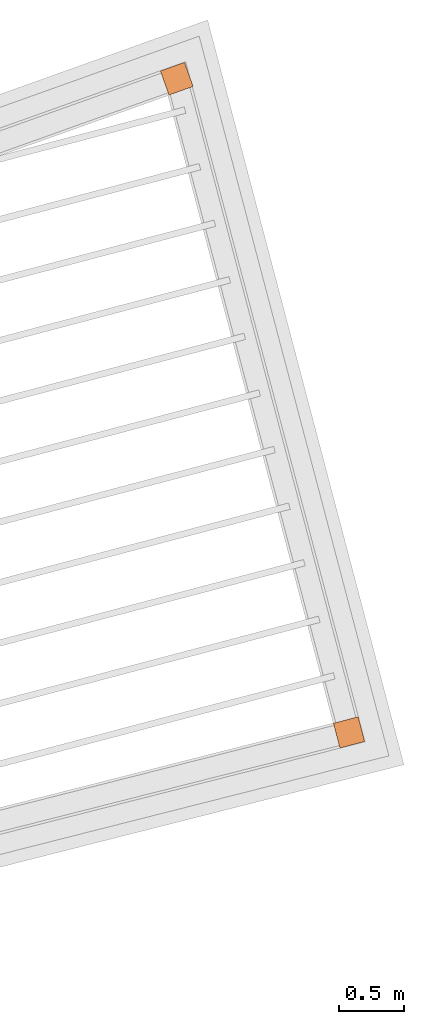
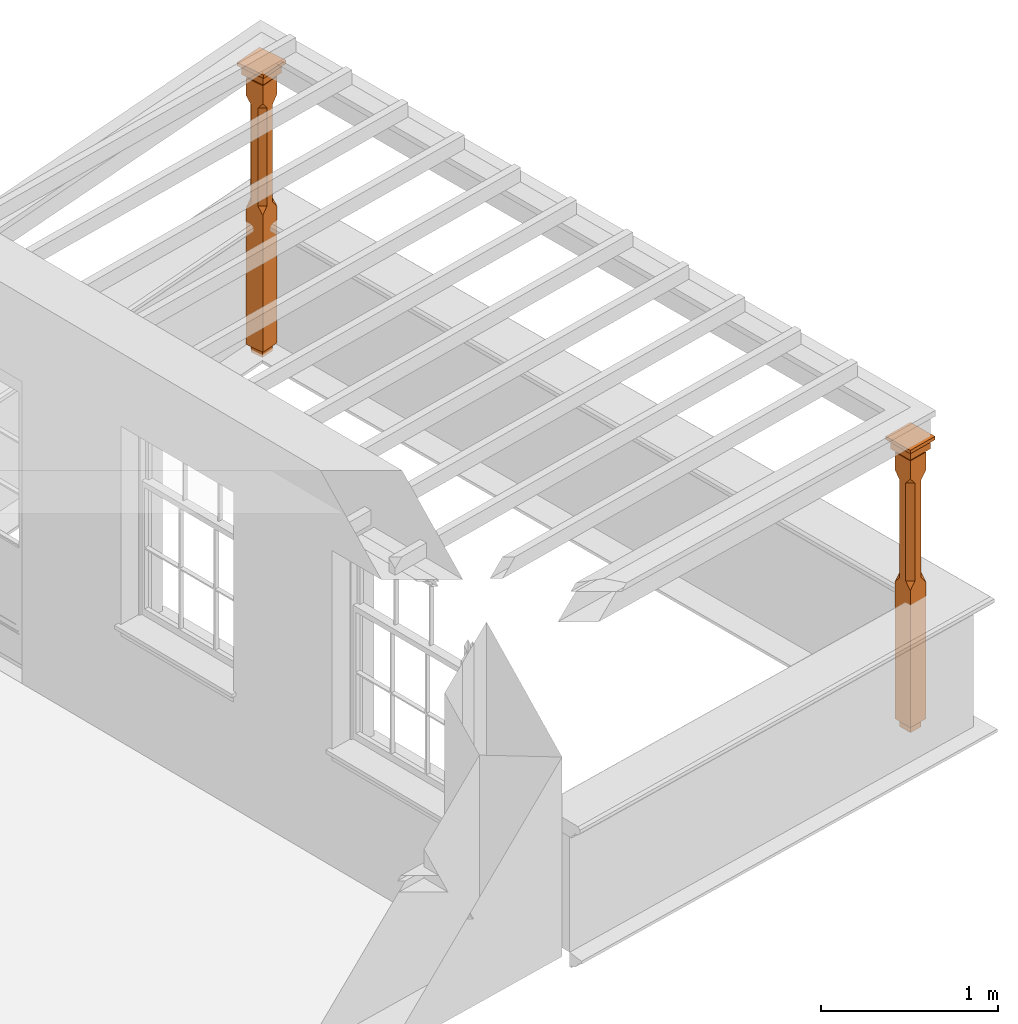
# One storey, part 10 of 10: 2 proxies.
"""IFC2X3 building model written with IfcOpenShell, lengths in metres."""

import ifcopenshell
import ifcopenshell.guid

model = None  # the IFC model being written
_history = None  # IfcOwnerHistory: only IFC2X3 demands one
_inside = {}  # id of a spatial element -> (the spatial element, [elements in it])
_under = {}  # id of a project, library or spatial element -> (it, [spatial elements below it])
_declared = {}  # id of a project -> (the project, [libraries it declares])
_typed = {}  # id of a type object -> (the type object, [elements of that type])
_made_of = {}  # id of a material, layer set ... -> (it, [elements and type objects made of it])


def new_model(schema):
    """Start an empty IFC model of exactly this schema.

    Asked for "IFC4X3", IfcOpenShell would pick the latest addendum, in which some entities
    have other attributes; the version numbers below select the first issue.
    IFC2X3 requires an IfcOwnerHistory on every rooted entity: one is made here for all.
    """
    global model, _history
    if schema == "IFC4X3":
        model = ifcopenshell.file(schema_version=(4, 3, 0, 0))
    else:
        model = ifcopenshell.file(schema=schema)
    _inside.clear()
    _under.clear()
    _declared.clear()
    _typed.clear()
    _made_of.clear()
    _history = None
    if model.schema == "IFC2X3":
        org = make("IfcOrganization", Name="unknown")
        user = make(
            "IfcPersonAndOrganization",
            ThePerson=make("IfcPerson", FamilyName="unknown"),
            TheOrganization=org,
        )
        app = make(
            "IfcApplication",
            ApplicationDeveloper=org,
            Version="unknown",
            ApplicationFullName="unknown",
            ApplicationIdentifier="unknown",
        )
        _history = make(
            "IfcOwnerHistory",
            OwningUser=user,
            OwningApplication=app,
            ChangeAction="ADDED",
            CreationDate=0,
        )
    return model


def make(cls, **values):
    """One entity of the class cls with the attributes given. An attribute that is None is left unset."""
    return model.create_entity(
        cls, **{name: value for name, value in values.items() if value is not None}
    )


def rooted(cls, **values):
    """An entity with a GlobalId (a new one), such as an element, a storey or a relation."""
    return make(cls, GlobalId=ifcopenshell.guid.new(), OwnerHistory=_history, **values)


def si_unit(unit_type, name, prefix=None):
    """IfcSIUnit, for example si_unit("LENGTHUNIT", "METRE", prefix="MILLI")."""
    return make("IfcSIUnit", UnitType=unit_type, Prefix=prefix, Name=name)


def assignment(units):
    """IfcUnitAssignment: the units of a project."""
    return None if units is None else make("IfcUnitAssignment", Units=units)


def point(xyz):
    """IfcCartesianPoint."""
    return None if xyz is None else make("IfcCartesianPoint", Coordinates=xyz)


def direction(xyz):
    """IfcDirection."""
    return None if xyz is None else make("IfcDirection", DirectionRatios=xyz)


def frame(location, z_axis=None, x_axis=None):
    """IfcAxis2Placement3D, a coordinate frame: its origin and axes. An axis left out is left unset."""
    return make(
        "IfcAxis2Placement3D",
        Location=point(location),
        Axis=direction(z_axis),
        RefDirection=direction(x_axis),
    )


def origin():
    """The frame at (0, 0, 0) with its axes left unset."""
    return frame((0.0, 0.0, 0.0))


def place(relative_to, where):
    """IfcLocalPlacement: puts the frame where relative to a parent placement (None: the world)."""
    return make(
        "IfcLocalPlacement", PlacementRelTo=relative_to, RelativePlacement=where
    )


def context(
    kind, dimensions, precision=None, world=None, true_north=None, identifier=None
):
    """IfcGeometricRepresentationContext, for example the 3D "Model" context."""
    return make(
        "IfcGeometricRepresentationContext",
        ContextIdentifier=identifier,
        ContextType=kind,
        CoordinateSpaceDimension=dimensions,
        Precision=precision,
        WorldCoordinateSystem=world,
        TrueNorth=true_north,
    )


def subcontext(parent, identifier, kind, view, scale=None):
    """IfcGeometricRepresentationSubContext, for example "Body" below "Model"."""
    return make(
        "IfcGeometricRepresentationSubContext",
        ContextIdentifier=identifier,
        ContextType=kind,
        ParentContext=parent,
        TargetScale=scale,
        TargetView=view,
    )


def project(units=None, contexts=None):
    """IfcProject with its units and contexts."""
    return rooted(
        "IfcProject",
        Name="project",
        RepresentationContexts=contexts,
        UnitsInContext=assignment(units),
    )


def spatial(cls, under=None, at=None, **own):
    """A site, building, storey or space (cls), placed at a placement, below another one or the project."""
    s = rooted(cls, ObjectPlacement=at, **own)
    if under is not None:
        _under.setdefault(under.id(), (under, []))[1].append(s)
    return s


def faces_of(points, faces, orient=None, outer=None):
    """IfcFace entities. A face is a list of loops; a loop is a list of indices into points, from 0.

    orient and outer hold one flag for each loop. By default every Orientation is true, the
    first loop of a face is its IfcFaceOuterBound and the others are IfcFaceBound.
    """
    made = []
    for i, loops in enumerate(faces):
        bounds = []
        for j, loop in enumerate(loops):
            is_outer = j == 0 if outer is None else outer[i][j]
            bounds.append(
                make(
                    "IfcFaceOuterBound" if is_outer else "IfcFaceBound",
                    Bound=make("IfcPolyLoop", Polygon=[points[k] for k in loop]),
                    Orientation=True if orient is None else orient[i][j],
                )
            )
        made.append(make("IfcFace", Bounds=bounds))
    return made


def faceted_brep(points, faces, orient=None, outer=None, voids=None):
    """IfcFacetedBrep: a solid bounded by flat faces; with voids (closed shells), ...WithVoids."""
    shared = [point(p) for p in points]
    hull = make("IfcClosedShell", CfsFaces=faces_of(shared, faces, orient, outer))
    if voids is None:
        return make("IfcFacetedBrep", Outer=hull)
    return make(
        "IfcFacetedBrepWithVoids",
        Outer=hull,
        Voids=[
            make(cls, CfsFaces=faces_of(shared, fs, o, b)) for cls, fs, o, b in voids
        ],
    )


def shape(context_of_items, identifier, shape_type, items):
    """IfcShapeRepresentation: the items that make up one representation, for example the "Body"."""
    return make(
        "IfcShapeRepresentation",
        ContextOfItems=context_of_items,
        RepresentationIdentifier=identifier,
        RepresentationType=shape_type,
        Items=items,
    )


def made_of(thing, what):
    """Note that an element or type object is made of a material, layer set ...; save() writes the relation."""
    if what is not None:
        _made_of.setdefault(what.id(), (what, []))[1].append(thing)
    return thing


def element(
    cls,
    number,
    at=None,
    inside=None,
    cuts=None,
    type_object=None,
    material=None,
    context=None,
    identifier="Body",
    shape_type=None,
    held_by="IfcProductDefinitionShape",
    body=None,
    shapes=None,
    **own,
):
    """One element of the class cls, such as IfcWall. Its Tag is "e" and its number.

    at: its placement. inside: the storey or other place that contains it. cuts: it is an
    opening in that element (IfcRelVoidsElement). A single representation is given by context,
    identifier, shape_type and body (its items); several are given by shapes. held_by: the class
    of the entity that holds the representations. save() writes the other relations.
    """
    e = rooted(cls, Tag="e%d" % number, ObjectPlacement=at, **own)
    if body is not None:
        shapes = [shape(context, identifier, shape_type, body)]
    if shapes is not None:
        e.Representation = make(held_by, Representations=shapes)
    if inside is not None:
        _inside.setdefault(inside.id(), (inside, []))[1].append(e)
    if cuts is not None:
        rooted(
            "IfcRelVoidsElement", RelatingBuildingElement=cuts, RelatedOpeningElement=e
        )
    if type_object is not None:
        _typed.setdefault(type_object.id(), (type_object, []))[1].append(e)
    return made_of(e, material)


def aggregate(whole, parts):
    """IfcRelAggregates: a whole, such as a stair, and the parts it consists of."""
    return rooted("IfcRelAggregates", RelatingObject=whole, RelatedObjects=parts)


def save(model, path):
    """Write the relations noted so far, then the file.

    IfcRelAggregates (storeys below a building ...), IfcRelContainedInSpatialStructure (elements
    in a storey), IfcRelDefinesByType, IfcRelAssociatesMaterial and IfcRelDeclares: one each for
    every whole, place, type object, material and project.
    """
    for whole, parts in _under.values():
        aggregate(whole, parts)
    for where, things in _inside.values():
        rooted(
            "IfcRelContainedInSpatialStructure",
            RelatedElements=things,
            RelatingStructure=where,
        )
    for kind, things in _typed.values():
        rooted("IfcRelDefinesByType", RelatedObjects=things, RelatingType=kind)
    for what, things in _made_of.values():
        rooted("IfcRelAssociatesMaterial", RelatedObjects=things, RelatingMaterial=what)
    for by, libraries in _declared.values():
        rooted("IfcRelDeclares", RelatingContext=by, RelatedDefinitions=libraries)
    model.write(path)


model = new_model("IFC2X3")

# Units and contexts
model_context = context("Model", 3, world=origin())
body_context = subcontext(model_context, "Body", "Model", "MODEL_VIEW")
ifc_project = project(units=[si_unit("PLANEANGLEUNIT", "RADIAN"), si_unit("MASSUNIT", "GRAM", prefix="KILO"), si_unit("FORCEUNIT", "NEWTON", prefix="KILO"), si_unit("LENGTHUNIT", "METRE")], contexts=[model_context])

# Site, building, storey
site_placement = place(None, origin())
site = spatial("IfcSite", under=ifc_project, at=site_placement, CompositionType="ELEMENT")
building_placement = place(None, origin())
building = spatial("IfcBuilding", under=site, at=building_placement, Name="Building plot-13", CompositionType="ELEMENT")
storey_placement = place(None, frame((0.0, 0.0, 9.55)))
storey = spatial("IfcBuildingStorey", under=building, at=storey_placement, Name="Floor 2", CompositionType="ELEMENT", Elevation=9.55)

# Proxies
proxy_1_placement = place(storey_placement, frame((80.0797172542298, 47.1910334064089, 0.0), z_axis=(0.0, 0.0, 1.0), x_axis=(-0.254909560380294, 0.96696489906652, 0.0)))
element("IfcBuildingElementProxy", 1, at=proxy_1_placement, inside=storey, Name="pergola post", CompositionType="ELEMENT", context=body_context, shape_type="Brep", held_by="IfcProductRepresentation", body=[
    faceted_brep([(0.0246, -0.0615, 1.72), (0.0615, -0.0246, 1.72), (0.0615, -0.0615, 1.766667), (0.0615, -0.0246, 1.044444), (0.0246, -0.0615, 1.044444), (0.0615, 0.0246, 1.72), (0.0615, 0.0615, 1.766667), (-0.0246, -0.0615, 1.72), (-0.0615, -0.0615, 1.766667), (-0.0246, -0.0615, 1.044444), (0.0615, -0.0615, 0.997778), (0.0615, 0.0246, 1.044444), (0.0246, 0.0615, 1.72), (0.0615, 0.0615, 1.891111), (0.0615, -0.0615, 1.891111), (-0.0615, -0.0615, 1.891111), (-0.0615, -0.0246, 1.72), (-0.0615, -0.0246, 1.044444), (-0.0615, -0.0615, 0.997778), (0.0615, 0.0615, 0.997778), (0.0246, 0.0615, 1.044444), (-0.0246, 0.0615, 1.72), (-0.0615, 0.0615, 1.766667), (0.04305, 0.04305, 1.891111), (0.04305, -0.04305, 1.891111), (-0.0615, 0.0615, 1.891111), (-0.04305, -0.04305, 1.891111), (-0.0615, 0.0246, 1.72), (-0.0615, 0.0246, 1.044444), (0.0615, -0.0615, 0.053333), (-0.0615, -0.0615, 0.053333), (0.0615, 0.0615, 0.053333), (-0.0246, 0.0615, 1.044444), (-0.04305, 0.04305, 1.891111), (0.04305, 0.04305, 1.914444), (0.04305, -0.04305, 1.914444), (-0.04305, -0.04305, 1.914444), (-0.0615, 0.0615, 0.997778), (-0.0615, 0.0615, 0.053333), (-0.04305, -0.04305, 0.053333), (0.04305, -0.04305, 0.053333), (0.04305, 0.04305, 0.053333), (-0.04305, 0.04305, 1.914444), (0.07995, 0.07995, 1.914444), (0.07995, -0.07995, 1.914444), (-0.07995, -0.07995, 1.914444), (-0.04305, 0.04305, 0.053333), (-0.04305, -0.04305, 0.0), (0.04305, -0.04305, 0.0), (0.04305, 0.04305, 0.0), (-0.07995, 0.07995, 1.914444), (0.07995, 0.07995, 1.976667), (0.07995, -0.07995, 1.976667), (-0.07995, -0.07995, 1.976667), (-0.04305, 0.04305, 0.0), (-0.07995, 0.07995, 1.976667), (0.0984, 0.0984, 1.976667), (0.0984, -0.0984, 1.976667), (-0.0984, -0.0984, 1.976667), (-0.0984, 0.0984, 1.976667), (0.0984, 0.0984, 2.0), (0.0984, -0.0984, 2.0), (-0.0984, -0.0984, 2.0), (-0.0984, 0.0984, 2.0)], [[[0, 1, 2]], [[3, 1, 0, 4]], [[1, 5, 6, 2]], [[7, 0, 2, 8]], [[4, 0, 7, 9]], [[3, 4, 10]], [[1, 3, 11, 5]], [[5, 12, 6]], [[13, 14, 2, 6]], [[15, 8, 2, 14]], [[8, 16, 7]], [[9, 7, 16, 17]], [[9, 18, 10, 4]], [[3, 10, 19, 11]], [[20, 12, 5, 11]], [[21, 22, 6, 12]], [[14, 13, 23, 24]], [[13, 6, 22, 25]], [[25, 22, 8, 15]], [[26, 15, 14, 24]], [[16, 8, 22, 27]], [[27, 28, 17, 16]], [[17, 18, 9]], [[29, 10, 18, 30]], [[31, 19, 10, 29]], [[20, 11, 19]], [[12, 20, 32, 21]], [[21, 27, 22]], [[33, 23, 13, 25]], [[23, 34, 35, 24]], [[26, 33, 25, 15]], [[36, 26, 24, 35]], [[28, 27, 21, 32]], [[17, 28, 37, 18]], [[38, 30, 18, 37]], [[29, 30, 39, 40]], [[31, 38, 37, 19]], [[40, 41, 31, 29]], [[32, 20, 19, 37]], [[33, 42, 34, 23]], [[43, 44, 35, 34]], [[42, 33, 26, 36]], [[36, 35, 44, 45]], [[28, 32, 37]], [[46, 39, 30, 38]], [[39, 47, 48, 40]], [[46, 38, 31, 41]], [[49, 41, 40, 48]], [[43, 34, 42, 50]], [[43, 51, 52, 44]], [[45, 50, 42, 36]], [[53, 45, 44, 52]], [[46, 54, 47, 39]], [[54, 46, 41, 49]], [[50, 55, 51, 43]], [[56, 57, 52, 51]], [[55, 50, 45, 53]], [[53, 52, 57, 58]], [[56, 51, 55, 59]], [[56, 60, 61, 57]], [[58, 59, 55, 53]], [[62, 58, 57, 61]], [[59, 63, 60, 56]], [[63, 62, 61, 60]], [[58, 62, 63, 59]], [[47, 54, 49, 48]]]),
])
proxy_2_placement = place(storey_placement, frame((78.7542279289787, 52.2190976723902, 0.0), z_axis=(0.0, 0.0, 1.0), x_axis=(-0.941614022472083, -0.336694271831203, 0.0)))
element("IfcBuildingElementProxy", 2, at=proxy_2_placement, inside=storey, Name="pergola post", CompositionType="ELEMENT", context=body_context, shape_type="Brep", held_by="IfcProductRepresentation", body=[
    faceted_brep([(0.0246, -0.0615, 1.72), (0.0615, -0.0246, 1.72), (0.0615, -0.0615, 1.766667), (0.0615, -0.0246, 1.044444), (0.0246, -0.0615, 1.044444), (0.0615, 0.0246, 1.72), (0.0615, 0.0615, 1.766667), (-0.0246, -0.0615, 1.72), (-0.0615, -0.0615, 1.766667), (-0.0246, -0.0615, 1.044444), (0.0615, -0.0615, 0.997778), (0.0615, 0.0246, 1.044444), (0.0246, 0.0615, 1.72), (0.0615, 0.0615, 1.891111), (0.0615, -0.0615, 1.891111), (-0.0615, -0.0615, 1.891111), (-0.0615, -0.0246, 1.72), (-0.0615, -0.0246, 1.044444), (-0.0615, -0.0615, 0.997778), (0.0615, 0.0615, 0.997778), (0.0246, 0.0615, 1.044444), (-0.0246, 0.0615, 1.72), (-0.0615, 0.0615, 1.766667), (0.04305, 0.04305, 1.891111), (0.04305, -0.04305, 1.891111), (-0.0615, 0.0615, 1.891111), (-0.04305, -0.04305, 1.891111), (-0.0615, 0.0246, 1.72), (-0.0615, 0.0246, 1.044444), (0.0615, -0.0615, 0.053333), (-0.0615, -0.0615, 0.053333), (0.0615, 0.0615, 0.053333), (-0.0246, 0.0615, 1.044444), (-0.04305, 0.04305, 1.891111), (0.04305, 0.04305, 1.914444), (0.04305, -0.04305, 1.914444), (-0.04305, -0.04305, 1.914444), (-0.0615, 0.0615, 0.997778), (-0.0615, 0.0615, 0.053333), (-0.04305, -0.04305, 0.053333), (0.04305, -0.04305, 0.053333), (0.04305, 0.04305, 0.053333), (-0.04305, 0.04305, 1.914444), (0.07995, 0.07995, 1.914444), (0.07995, -0.07995, 1.914444), (-0.07995, -0.07995, 1.914444), (-0.04305, 0.04305, 0.053333), (-0.04305, -0.04305, 0.0), (0.04305, -0.04305, 0.0), (0.04305, 0.04305, 0.0), (-0.07995, 0.07995, 1.914444), (0.07995, 0.07995, 1.976667), (0.07995, -0.07995, 1.976667), (-0.07995, -0.07995, 1.976667), (-0.04305, 0.04305, 0.0), (-0.07995, 0.07995, 1.976667), (0.0984, 0.0984, 1.976667), (0.0984, -0.0984, 1.976667), (-0.0984, -0.0984, 1.976667), (-0.0984, 0.0984, 1.976667), (0.0984, 0.0984, 2.0), (0.0984, -0.0984, 2.0), (-0.0984, -0.0984, 2.0), (-0.0984, 0.0984, 2.0)], [[[0, 1, 2]], [[3, 1, 0, 4]], [[1, 5, 6, 2]], [[7, 0, 2, 8]], [[4, 0, 7, 9]], [[3, 4, 10]], [[1, 3, 11, 5]], [[5, 12, 6]], [[13, 14, 2, 6]], [[15, 8, 2, 14]], [[8, 16, 7]], [[9, 7, 16, 17]], [[9, 18, 10, 4]], [[3, 10, 19, 11]], [[20, 12, 5, 11]], [[21, 22, 6, 12]], [[14, 13, 23, 24]], [[13, 6, 22, 25]], [[25, 22, 8, 15]], [[26, 15, 14, 24]], [[16, 8, 22, 27]], [[27, 28, 17, 16]], [[17, 18, 9]], [[29, 10, 18, 30]], [[31, 19, 10, 29]], [[20, 11, 19]], [[12, 20, 32, 21]], [[21, 27, 22]], [[33, 23, 13, 25]], [[23, 34, 35, 24]], [[26, 33, 25, 15]], [[36, 26, 24, 35]], [[28, 27, 21, 32]], [[17, 28, 37, 18]], [[38, 30, 18, 37]], [[29, 30, 39, 40]], [[31, 38, 37, 19]], [[40, 41, 31, 29]], [[32, 20, 19, 37]], [[33, 42, 34, 23]], [[43, 44, 35, 34]], [[42, 33, 26, 36]], [[36, 35, 44, 45]], [[28, 32, 37]], [[46, 39, 30, 38]], [[39, 47, 48, 40]], [[46, 38, 31, 41]], [[49, 41, 40, 48]], [[43, 34, 42, 50]], [[43, 51, 52, 44]], [[45, 50, 42, 36]], [[53, 45, 44, 52]], [[46, 54, 47, 39]], [[54, 46, 41, 49]], [[50, 55, 51, 43]], [[56, 57, 52, 51]], [[55, 50, 45, 53]], [[53, 52, 57, 58]], [[56, 51, 55, 59]], [[56, 60, 61, 57]], [[58, 59, 55, 53]], [[62, 58, 57, 61]], [[59, 63, 60, 56]], [[63, 62, 61, 60]], [[58, 62, 63, 59]], [[47, 54, 49, 48]]]),
])

save(model, "model.ifc")
